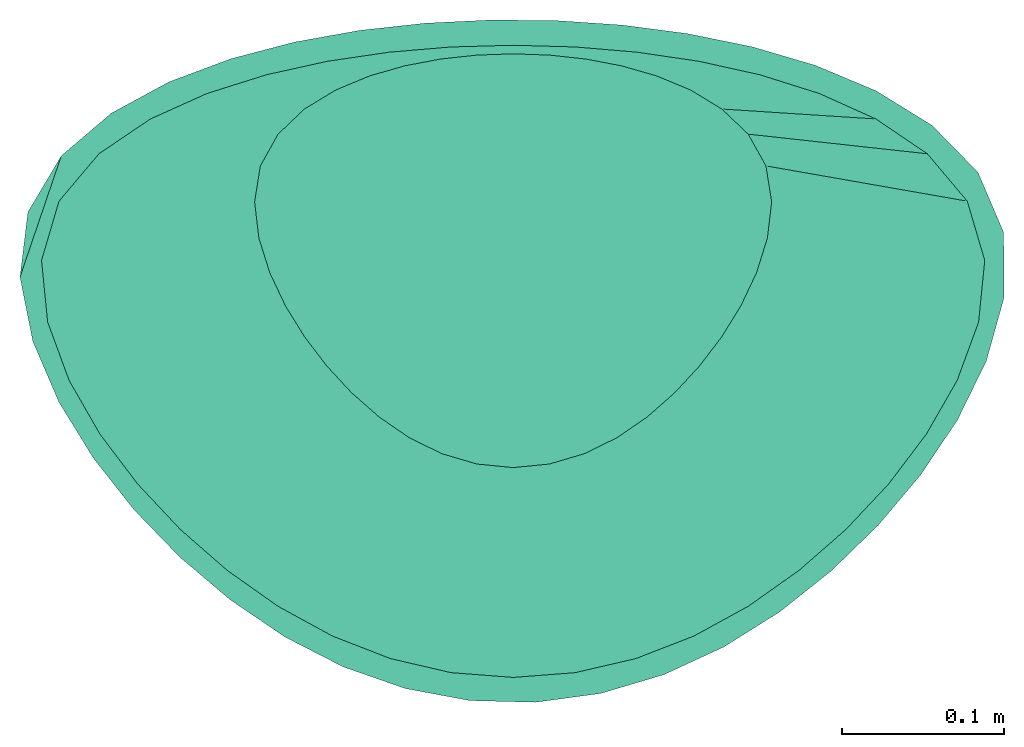
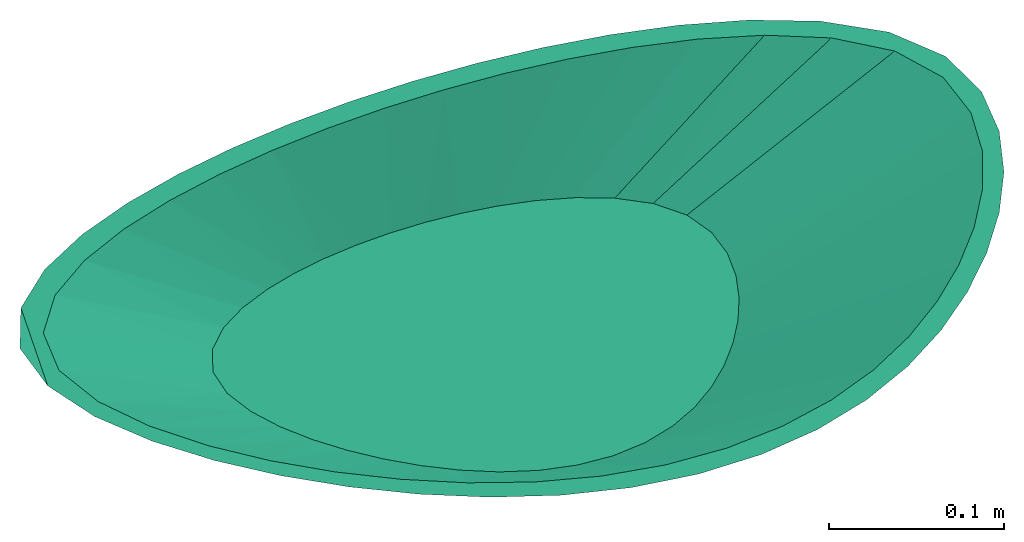
# Not in any storey: 1 sanitary terminal.
"""IFC4 building model written with IfcOpenShell, lengths in millimetres."""

from ifc_helpers import new_model, si_unit, direction, origin, place, context, subcontext, project, spatial, faceted_brep, source, transform, mapped, material, type_object, type_shapes, element, save


model = new_model("IFC4")

# Units and contexts
model_context_1 = context("Model", 3, precision=0.0001, world=origin(), true_north=direction((0.0, 1.0)))
model_context_2 = context("Model", 3, precision=0.0001, world=origin(), true_north=direction((0.0, 1.0)))
body_context = subcontext(model_context_1, "Body", "Model", "MODEL_VIEW")
ifc_project = project(units=[si_unit("LENGTHUNIT", "METRE", prefix="MILLI"), si_unit("PLANEANGLEUNIT", "RADIAN"), si_unit("TIMEUNIT", "SECOND")], contexts=[model_context_2])

# Building
building_placement = place(None, origin())
building = spatial("IfcBuilding", under=ifc_project, at=building_placement, Name="IfcBuilding", CompositionType="ELEMENT")

# Sanitary terminal
ifc_material = material(Name="Ceramic")
sanitary_terminal_type = type_object("IfcSanitaryTerminalType", PredefinedType="WASHHANDBASIN", material=ifc_material)
shared_shape = source(origin(), body_context, "Body", "Brep", [
    faceted_brep([(-304.891071307496, 109.822256120206, 0.0), (-296.940075211924, 69.9862810835965, 0.0), (-280.922701731312, 32.5907488402735, 0.0), (-259.608278768049, -2.08529338102262, 0.0), (-234.428168068557, -34.0753473673235, 0.0), (-206.125816386308, -63.3430855287523, 0.0), (-175.071534188435, -89.671802213621, 0.0), (-141.412934526735, -112.569598180375, 0.0), (-105.215114341225, -131.178510124149, 0.0), (-66.7978479682479, -144.600522500239, 0.0), (-26.8019125425913, -152.078206375312, 0.0), (13.8710862775596, -153.121660363236, 0.0), (54.1903326227934, -147.658103330519, 0.0), (93.1938862047157, -136.056391059388, 0.0), (130.150407237097, -119.008883827061, 0.0), (164.629900262907, -97.37165169902, 0.0), (196.521914802755, -72.0656434367093, 0.0), (225.728273711876, -43.6997637700286, 0.0), (251.961645534009, -12.5658965535741, 0.0), (274.62087031373, 21.2509318856294, 0.0), (292.544561947164, 57.7814080324017, 0.0), (303.485368351088, 96.9291090994897, 0.0), (303.288957242437, 137.460278743209, 0.0), (287.369755242598, 174.609406522514, 0.0), (258.965081713391, 203.584218912768, 0.0), (224.363000998313, 224.953681400811, 0.0), (186.818017180943, 240.67163971588, 0.0), (147.756154156487, 252.155742473922, 0.0), (107.854433144861, 260.280582237886, 0.0), (67.4765332607867, 265.571769764524, 0.0), (26.8458427708863, 268.331827033896, 0.0), (-13.8771780303431, 268.706812331913, 0.0), (-54.5530293999268, 266.715969920949, 0.0), (-95.0316202590492, 262.255497380798, 0.0), (-135.115612880362, 255.077835581894, 0.0), (-174.498313981775, 244.738726835566, 0.0), (-212.631973130034, 230.493081814022, 0.0), (-248.405687646327, 211.118276332925, 0.0), (-279.319862190373, 184.775801315119, 0.0), (38.4756983219429, 252.033478287557, 0.0), (76.82797079471, 248.781505427916, 0.0), (114.905040261981, 243.168611097888, 0.0), (152.483825019629, 234.862972697005, 0.0), (189.184260308893, 223.297735395069, 0.0), (224.265826794532, 207.523990642274, 0.0), (256.087669717028, 185.991172830599, 0.0), (280.765071736094, 156.699063336262, 0.0), (291.585141614082, 120.093338245881, 0.0), (287.786485451514, 81.9448662146907, 0.0), (274.528157897687, 45.8738463140147, 0.0), (255.376512280737, 12.5180862102588, 0.0), (232.162082007755, -18.1641105843033, 0.0), (205.82058249047, -46.2135089189517, 0.0), (176.831543285532, -71.5181976728152, 0.0), (145.419108882987, -93.7387882260769, 0.0), (111.672515835794, -112.209605260782, 0.0), (75.812198248967, -126.124204222316, 0.0), (38.3440539351622, -134.804771445296, 0.0), (5.62489231925e-06, -137.758996454453, 0.0), (-38.3440494938959, -134.804772131387, 0.0), (-75.8121974100292, -126.124204482417, 0.0), (-111.672515690142, -112.209605328934, 0.0), (-145.419108622881, -93.7387883895915, 0.0), (-176.831543103321, -71.5181978165611, 0.0), (-205.820584751455, -46.2135067401479, 0.0), (-232.162080231681, -18.164112680286, 0.0), (-255.37651255073, 12.5180866141667, 0.0), (-274.528157992219, 45.8738465115148, 0.0), (-287.786482832935, 81.9448557189429, 0.0), (-291.585141527273, 120.093339480335, 0.0), (-280.765069841138, 156.69906670217, 0.0), (-256.087676107765, 185.991167334279, 0.0), (-224.265825523088, 207.523991330957, 0.0), (-189.184272565133, 223.297730817421, 0.0), (-152.483829695455, 234.862971464014, 0.0), (-114.905033181042, 243.168612385642, 0.0), (-76.8279738129532, 248.781505081298, 0.0), (-38.4757029862493, 252.0334780278, 0.0), (0.0, 253.099263998677, 0.0), (-159.799786377107, 153.46782071584, -93.9999999999991), (-156.563435238971, 131.153861277019, -93.9999999999991), (-149.376131896764, 109.760102145713, -93.9999999999991), (-139.405144871723, 89.5038839334345, -93.9999999999991), (-127.294335499358, 70.445523587566, -93.9999999999991), (-113.387459490709, 52.6538727330131, -93.9999999999991), (-97.8447661146846, 36.2725918775068, -93.9999999999991), (-80.698001162248, 21.582584637739, -93.9999999999991), (-61.8871867593298, 9.10501350136987, -93.9999999999991), (-41.4394014166823, -0.440153063918815, -93.9999999999991), (-19.662998563232, -6.32985285628291, -93.9999999999991), (2.83012817778957, -7.98927385674093, -93.9999999999991), (25.2161298976784, -5.23363177905661, -93.9999999999991), (46.7052656338443, 1.63611866403177, -93.9999999999991), (66.7603568037461, 11.9848882796374, -93.9999999999991), (85.1475914236449, 25.0817028555501, -93.9999999999991), (101.889510015946, 40.2328202653944, -93.9999999999991), (117.029708390029, 56.9871779332136, -93.9999999999991), (130.507477385555, 75.1059075118196, -93.9999999999991), (142.123444996071, 94.4691487187488, -93.9999999999991), (151.473017550452, 115.017962619083, -93.9999999999991), (157.807019966901, 136.675894195075, -93.9999999999991), (159.780564770642, 159.127525554679, -93.9999999999991), (155.311843754385, 181.158856579337, -93.9999999999991), (143.527109004701, 200.308104946409, -93.9999999999991), (126.728646947386, 215.328663366711, -93.9999999999991), (107.202467334812, 226.634520930962, -93.9999999999991), (86.2268790106761, 234.98230335346, -93.9999999999991), (64.4507343905464, 240.958334023702, -93.9999999999991), (42.2218098296953, 244.946818741202, -93.9999999999991), (19.7473348710258, 247.180277362528, -93.9999999999991), (-2.83037829161053, 247.779902642456, -93.9999999999991), (-25.3937160660832, 246.777117598331, -93.9999999999991), (-47.8217104720131, 244.119106659353, -93.9999999999991), (-69.9604240039862, 239.659498513825, -93.9999999999991), (-91.576683901205, 233.132310979361, -93.9999999999991), (-112.267364103545, 224.107056891456, -93.9999999999991), (-131.264894314891, 211.943402767825, -93.9999999999991), (-147.061746316906, 195.888143420344, -93.9999999999991), (-157.154914340418, 175.808617178122, -93.9999999999991), (-22.5714426203723, 246.991542511388, -83.9999999999991), (-45.0238143941789, 244.546840992317, -83.9999999999991), (-67.2093088278616, 240.324720105693, -83.9999999999991), (-88.9083392880943, 234.076268171425, -83.9999999999991), (-109.746783760019, 225.394569776618, -83.9999999999991), (-129.019214178155, 213.666092805292, -83.9999999999991), (-145.336255413146, 198.131561931792, -83.9999999999991), (-156.295574267743, 178.505166800292, -83.9999999999991), (-159.838406313243, 156.297849730896, -83.9999999999991), (-157.217231378449, 133.907674702395, -83.9999999999991), (-150.446948503868, 112.380106954109, -83.9999999999991), (-140.781370993691, 91.9771671791993, -83.9999999999991), (-128.915130782292, 72.7659081552236, -83.9999999999991), (-115.221432502533, 54.8097171953257, -83.9999999999991), (-99.8796470071603, 38.239929890392, -83.9999999999991), (-82.9357654214438, 23.3156500424069, -83.9999999999991), (-64.3369337417203, 10.5226649501159, -83.9999999999991), (-44.0834019165823, 0.569910981625322, -83.9999999999991), (-22.4460832273862, -5.81475796938246, -83.9999999999991), (1.76219393597e-06, -8.0243005407274, -83.9999999999991), (22.446084481302, -5.81475772180151, -83.9999999999991), (44.0834024872804, 0.569911206685156, -83.9999999999991), (64.3369357795818, 10.5226661545967, -83.9999999999991), (82.9357630974296, 23.3156482145766, -83.9999999999991), (99.8796474348905, 38.2399303092091, -83.9999999999991), (115.221437914664, 54.8097236343718, -83.9999999999991), (128.915131219959, 72.7659087899957, -83.9999999999991), (140.781372023645, 91.9771690603084, -83.9999999999991), (150.44694977305, 112.380110135675, -83.9999999999991), (157.217230633118, 133.907671395464, -83.9999999999991), (159.838406320187, 156.297847499286, -83.9999999999991), (156.295574340587, 178.505166588871, -83.9999999999991), (145.336254078924, 198.131563599338, -83.9999999999991), (129.019208284081, 213.666097201998, -83.9999999999991), (109.746785929842, 225.394568694178, -83.9999999999991), (88.90833880495, 234.07626833846, -83.9999999999991), (67.2093069026739, 240.324720559443, -83.9999999999991), (45.0238122743352, 244.546841305597, -83.9999999999991), (22.5714426167356, 246.991542511648, -83.9999999999991), (0.0, 247.792422124388, -83.9999999999991), (-300.0, 150.0, 0.0)], [[[0, 1, 2, 3, 4, 5, 6, 7, 8, 9, 10, 11, 12, 13, 14, 15, 16, 17, 18, 19, 20, 21, 22, 23, 24, 25, 26, 27, 28, 29, 30, 31, 32, 33, 34, 35, 36, 37, 38], [39, 40, 41, 42, 43, 44, 45, 46, 47, 48, 49, 50, 51, 52, 53, 54, 55, 56, 57, 58, 59, 60, 61, 62, 63, 64, 65, 66, 67, 68, 69, 70, 71, 72, 73, 74, 75, 76, 77, 78]], [[79, 80, 81, 82, 83, 84, 85, 86, 87, 88, 89, 90, 91, 92, 93, 94, 95, 96, 97, 98, 99, 100, 101, 102, 103, 104, 105, 106, 107, 108, 109, 110, 111, 112, 113, 114, 115, 116, 117, 118]], [[119, 120, 121, 122, 123, 124, 125, 126, 127, 128, 129, 130, 131, 132, 133, 134, 135, 136, 137, 138, 139, 140, 141, 142, 143, 144, 145, 146, 147, 148, 149, 150, 151, 152, 153, 154, 155, 156, 157, 158]], [[159, 117, 118]], [[38, 116, 117]], [[37, 115, 116]], [[36, 114, 115]], [[35, 113, 114]], [[34, 112, 113]], [[33, 111, 112]], [[32, 110, 111]], [[31, 109, 110]], [[30, 108, 109]], [[29, 107, 108]], [[28, 106, 107]], [[27, 105, 106]], [[26, 104, 105]], [[25, 103, 104]], [[24, 102, 103]], [[23, 101, 102]], [[22, 100, 101]], [[21, 99, 100]], [[20, 98, 99]], [[19, 97, 98]], [[18, 96, 97]], [[17, 95, 96]], [[16, 94, 95]], [[15, 93, 94]], [[14, 92, 93]], [[13, 91, 92]], [[12, 90, 91]], [[11, 89, 90]], [[10, 88, 89]], [[9, 87, 88]], [[8, 86, 87]], [[7, 85, 86]], [[6, 84, 85]], [[5, 83, 84]], [[4, 82, 83]], [[3, 81, 82]], [[2, 80, 81]], [[1, 79, 80]], [[0, 118, 79]], [[159, 38, 117]], [[38, 37, 116]], [[37, 36, 115]], [[36, 35, 114]], [[35, 34, 113]], [[34, 33, 112]], [[33, 32, 111]], [[32, 31, 110]], [[31, 30, 109]], [[30, 29, 108]], [[29, 28, 107]], [[28, 27, 106]], [[27, 26, 105]], [[26, 25, 104]], [[25, 24, 103]], [[24, 23, 102]], [[23, 22, 101]], [[22, 21, 100]], [[21, 20, 99]], [[20, 19, 98]], [[19, 18, 97]], [[18, 17, 96]], [[17, 16, 95]], [[16, 15, 94]], [[15, 14, 93]], [[14, 13, 92]], [[13, 12, 91]], [[12, 11, 90]], [[11, 10, 89]], [[10, 9, 88]], [[9, 8, 87]], [[8, 7, 86]], [[7, 6, 85]], [[6, 5, 84]], [[5, 4, 83]], [[4, 3, 82]], [[3, 2, 81]], [[2, 1, 80]], [[1, 0, 79]], [[0, 159, 118]], [[78, 157, 158]], [[39, 156, 157]], [[40, 155, 156]], [[41, 154, 155]], [[42, 153, 154]], [[43, 152, 153]], [[44, 151, 152]], [[45, 150, 151]], [[46, 149, 150]], [[47, 148, 149]], [[48, 147, 148]], [[49, 146, 147]], [[50, 145, 146]], [[51, 144, 145]], [[52, 143, 144]], [[53, 142, 143]], [[54, 141, 142]], [[55, 140, 141]], [[56, 139, 140]], [[57, 138, 139]], [[58, 137, 138]], [[59, 136, 137]], [[60, 135, 136]], [[61, 134, 135]], [[62, 133, 134]], [[63, 132, 133]], [[64, 131, 132]], [[65, 130, 131]], [[66, 129, 130]], [[67, 128, 129]], [[68, 127, 128]], [[69, 126, 127]], [[70, 125, 126]], [[71, 124, 125]], [[72, 123, 124]], [[73, 122, 123]], [[74, 121, 122]], [[75, 120, 121]], [[76, 119, 120]], [[77, 158, 119]], [[78, 39, 157]], [[39, 40, 156]], [[40, 41, 155]], [[41, 42, 154]], [[42, 43, 153]], [[43, 44, 152]], [[44, 45, 151]], [[45, 46, 150]], [[46, 47, 149]], [[47, 48, 148]], [[48, 49, 147]], [[49, 50, 146]], [[50, 51, 145]], [[51, 52, 144]], [[52, 53, 143]], [[53, 54, 142]], [[54, 55, 141]], [[55, 56, 140]], [[56, 57, 139]], [[57, 58, 138]], [[58, 59, 137]], [[59, 60, 136]], [[60, 61, 135]], [[61, 62, 134]], [[62, 63, 133]], [[63, 64, 132]], [[64, 65, 131]], [[65, 66, 130]], [[66, 67, 129]], [[67, 68, 128]], [[68, 69, 127]], [[69, 70, 126]], [[70, 71, 125]], [[71, 72, 124]], [[72, 73, 123]], [[73, 74, 122]], [[74, 75, 121]], [[75, 76, 120]], [[76, 77, 119]], [[77, 78, 158]]]),
])
type_shapes(sanitary_terminal_type, [shared_shape])
sanitary_terminal_placement = place(building_placement, origin())
element("IfcSanitaryTerminal", 1, at=sanitary_terminal_placement, inside=building, type_object=sanitary_terminal_type, PredefinedType="NOTDEFINED", context=body_context, shape_type="MappedRepresentation", body=[
    mapped(shared_shape, transform((0.0, 0.0, 0.0), x_axis=(1.0, 0.0, 0.0), y_axis=(0.0, 1.0, 0.0), z_axis=(0.0, 0.0, 1.0), scale=1.0)),
])

save(model, "model.ifc")
